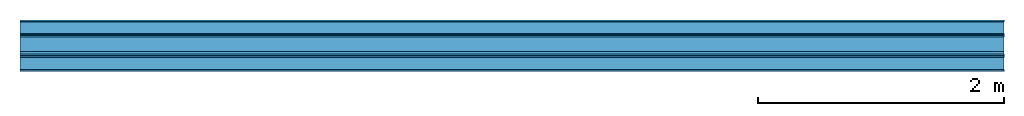
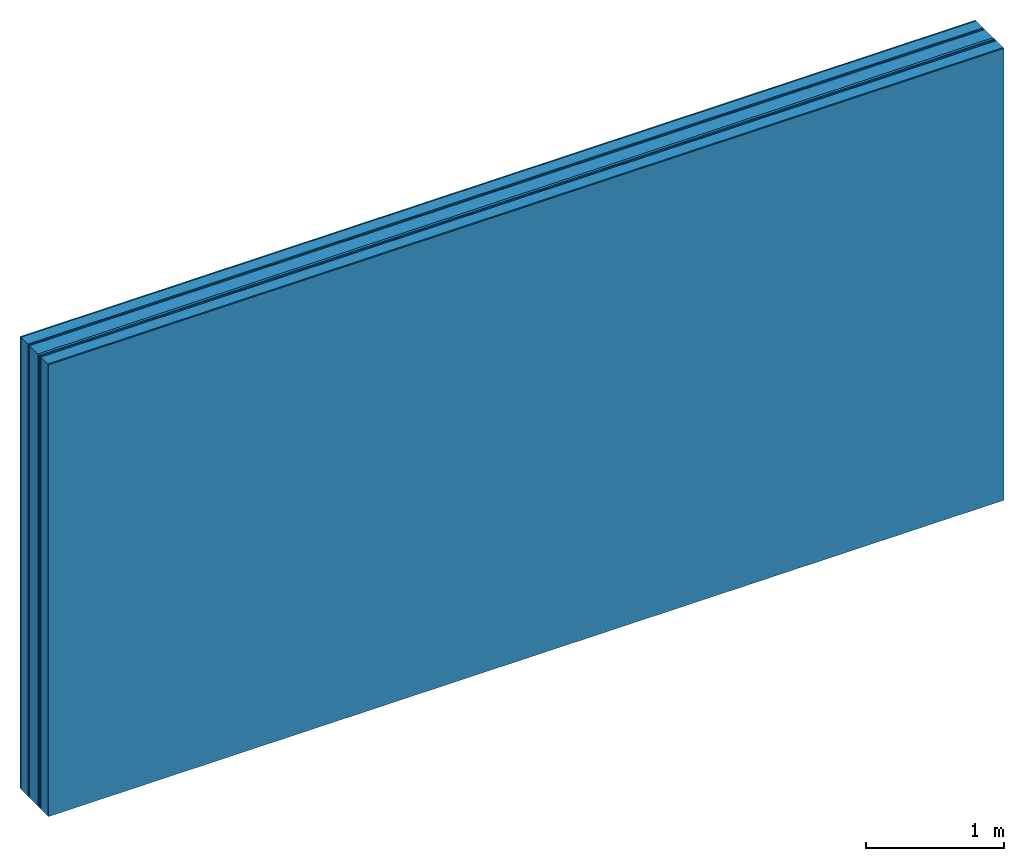
# One storey: 8 plates, 2 members, 1 element without a shape of its own.
"""IFC4 building model written with IfcOpenShell, lengths in metres."""

import ifcopenshell
import ifcopenshell.guid

model = None  # the IFC model being written
_history = None  # IfcOwnerHistory: only IFC2X3 demands one
_inside = {}  # id of a spatial element -> (the spatial element, [elements in it])
_under = {}  # id of a project, library or spatial element -> (it, [spatial elements below it])
_declared = {}  # id of a project -> (the project, [libraries it declares])
_typed = {}  # id of a type object -> (the type object, [elements of that type])
_made_of = {}  # id of a material, layer set ... -> (it, [elements and type objects made of it])


def new_model(schema):
    """Start an empty IFC model of exactly this schema.

    Asked for "IFC4X3", IfcOpenShell would pick the latest addendum, in which some entities
    have other attributes; the version numbers below select the first issue.
    IFC2X3 requires an IfcOwnerHistory on every rooted entity: one is made here for all.
    """
    global model, _history
    if schema == "IFC4X3":
        model = ifcopenshell.file(schema_version=(4, 3, 0, 0))
    else:
        model = ifcopenshell.file(schema=schema)
    _inside.clear()
    _under.clear()
    _declared.clear()
    _typed.clear()
    _made_of.clear()
    _history = None
    if model.schema == "IFC2X3":
        org = make("IfcOrganization", Name="unknown")
        user = make(
            "IfcPersonAndOrganization",
            ThePerson=make("IfcPerson", FamilyName="unknown"),
            TheOrganization=org,
        )
        app = make(
            "IfcApplication",
            ApplicationDeveloper=org,
            Version="unknown",
            ApplicationFullName="unknown",
            ApplicationIdentifier="unknown",
        )
        _history = make(
            "IfcOwnerHistory",
            OwningUser=user,
            OwningApplication=app,
            ChangeAction="ADDED",
            CreationDate=0,
        )
    return model


def make(cls, **values):
    """One entity of the class cls with the attributes given. An attribute that is None is left unset."""
    return model.create_entity(
        cls, **{name: value for name, value in values.items() if value is not None}
    )


def rooted(cls, **values):
    """An entity with a GlobalId (a new one), such as an element, a storey or a relation."""
    return make(cls, GlobalId=ifcopenshell.guid.new(), OwnerHistory=_history, **values)


def si_unit(unit_type, name, prefix=None):
    """IfcSIUnit, for example si_unit("LENGTHUNIT", "METRE", prefix="MILLI")."""
    return make("IfcSIUnit", UnitType=unit_type, Prefix=prefix, Name=name)


def derived_unit(unit_type, elements):
    """IfcDerivedUnit: a product of units, each with its exponent."""
    return make(
        "IfcDerivedUnit",
        Elements=[
            make("IfcDerivedUnitElement", Unit=unit, Exponent=power)
            for unit, power in elements
        ],
        UnitType=unit_type,
    )


def assignment(units):
    """IfcUnitAssignment: the units of a project."""
    return None if units is None else make("IfcUnitAssignment", Units=units)


def point(xyz):
    """IfcCartesianPoint."""
    return None if xyz is None else make("IfcCartesianPoint", Coordinates=xyz)


def direction(xyz):
    """IfcDirection."""
    return None if xyz is None else make("IfcDirection", DirectionRatios=xyz)


def frame(location, z_axis=None, x_axis=None):
    """IfcAxis2Placement3D, a coordinate frame: its origin and axes. An axis left out is left unset."""
    return make(
        "IfcAxis2Placement3D",
        Location=point(location),
        Axis=direction(z_axis),
        RefDirection=direction(x_axis),
    )


def frame_2d(location, x_axis=None):
    """IfcAxis2Placement2D, a coordinate frame in the plane: its origin and x axis."""
    return make(
        "IfcAxis2Placement2D", Location=point(location), RefDirection=direction(x_axis)
    )


def origin():
    """The frame at (0, 0, 0) with its axes left unset."""
    return frame((0.0, 0.0, 0.0))


def origin_with_axes():
    """The frame at (0, 0, 0) with the z axis (0, 0, 1) and the x axis (1, 0, 0) written out."""
    return frame((0.0, 0.0, 0.0), z_axis=(0.0, 0.0, 1.0), x_axis=(1.0, 0.0, 0.0))


def place(relative_to, where):
    """IfcLocalPlacement: puts the frame where relative to a parent placement (None: the world)."""
    return make(
        "IfcLocalPlacement", PlacementRelTo=relative_to, RelativePlacement=where
    )


def context(
    kind, dimensions, precision=None, world=None, true_north=None, identifier=None
):
    """IfcGeometricRepresentationContext, for example the 3D "Model" context."""
    return make(
        "IfcGeometricRepresentationContext",
        ContextIdentifier=identifier,
        ContextType=kind,
        CoordinateSpaceDimension=dimensions,
        Precision=precision,
        WorldCoordinateSystem=world,
        TrueNorth=true_north,
    )


def project(units=None, contexts=None):
    """IfcProject with its units and contexts."""
    return rooted(
        "IfcProject",
        Name="project",
        RepresentationContexts=contexts,
        UnitsInContext=assignment(units),
    )


def spatial(cls, under=None, at=None, **own):
    """A site, building, storey or space (cls), placed at a placement, below another one or the project."""
    s = rooted(cls, ObjectPlacement=at, **own)
    if under is not None:
        _under.setdefault(under.id(), (under, []))[1].append(s)
    return s


def profile(cls, at=None, kind="AREA", **sizes):
    """A parametric profile (cls). Its sizes go by their IFC names, for example OverallWidth=200.0."""
    return make(cls, ProfileType=kind, Position=at, **sizes)


def rectangle(**sizes):
    """IfcRectangleProfileDef."""
    return profile("IfcRectangleProfileDef", **sizes)


def extrude(swept, where, along, depth):
    """IfcExtrudedAreaSolid: the profile swept, set in the frame where, extruded along a direction by depth."""
    return make(
        "IfcExtrudedAreaSolid",
        SweptArea=swept,
        Position=where,
        ExtrudedDirection=direction(along),
        Depth=depth,
    )


def shape(context_of_items, identifier, shape_type, items):
    """IfcShapeRepresentation: the items that make up one representation, for example the "Body"."""
    return make(
        "IfcShapeRepresentation",
        ContextOfItems=context_of_items,
        RepresentationIdentifier=identifier,
        RepresentationType=shape_type,
        Items=items,
    )


def material(Name=None, Category=None):
    """IfcMaterial."""
    return make("IfcMaterial", Name=Name, Category=Category)


def layer(
    of_material, thickness, ventilated=None, Name=None, Category=None, Priority=None
):
    """IfcMaterialLayer: one layer of a wall or slab, of a material (None: an air gap)."""
    return make(
        "IfcMaterialLayer",
        Material=of_material,
        LayerThickness=thickness,
        IsVentilated=ventilated,
        Name=Name,
        Category=Category,
        Priority=Priority,
    )


def layer_set(layers, Name=None):
    """IfcMaterialLayerSet."""
    return make("IfcMaterialLayerSet", MaterialLayers=layers, LayerSetName=Name)


def made_of(thing, what):
    """Note that an element or type object is made of a material, layer set ...; save() writes the relation."""
    if what is not None:
        _made_of.setdefault(what.id(), (what, []))[1].append(thing)
    return thing


def type_object(cls, material=None, **own):
    """A type object (cls), such as IfcWallType, which elements share."""
    return made_of(rooted(cls, **own), material)


def element(
    cls,
    number,
    at=None,
    inside=None,
    cuts=None,
    type_object=None,
    material=None,
    context=None,
    identifier="Body",
    shape_type=None,
    held_by="IfcProductDefinitionShape",
    body=None,
    shapes=None,
    **own,
):
    """One element of the class cls, such as IfcWall. Its Tag is "e" and its number.

    at: its placement. inside: the storey or other place that contains it. cuts: it is an
    opening in that element (IfcRelVoidsElement). A single representation is given by context,
    identifier, shape_type and body (its items); several are given by shapes. held_by: the class
    of the entity that holds the representations. save() writes the other relations.
    """
    e = rooted(cls, Tag="e%d" % number, ObjectPlacement=at, **own)
    if body is not None:
        shapes = [shape(context, identifier, shape_type, body)]
    if shapes is not None:
        e.Representation = make(held_by, Representations=shapes)
    if inside is not None:
        _inside.setdefault(inside.id(), (inside, []))[1].append(e)
    if cuts is not None:
        rooted(
            "IfcRelVoidsElement", RelatingBuildingElement=cuts, RelatedOpeningElement=e
        )
    if type_object is not None:
        _typed.setdefault(type_object.id(), (type_object, []))[1].append(e)
    return made_of(e, material)


def aggregate(whole, parts):
    """IfcRelAggregates: a whole, such as a stair, and the parts it consists of."""
    return rooted("IfcRelAggregates", RelatingObject=whole, RelatedObjects=parts)


def save(model, path):
    """Write the relations noted so far, then the file.

    IfcRelAggregates (storeys below a building ...), IfcRelContainedInSpatialStructure (elements
    in a storey), IfcRelDefinesByType, IfcRelAssociatesMaterial and IfcRelDeclares: one each for
    every whole, place, type object, material and project.
    """
    for whole, parts in _under.values():
        aggregate(whole, parts)
    for where, things in _inside.values():
        rooted(
            "IfcRelContainedInSpatialStructure",
            RelatedElements=things,
            RelatingStructure=where,
        )
    for kind, things in _typed.values():
        rooted("IfcRelDefinesByType", RelatedObjects=things, RelatingType=kind)
    for what, things in _made_of.values():
        rooted("IfcRelAssociatesMaterial", RelatedObjects=things, RelatingMaterial=what)
    for by, libraries in _declared.values():
        rooted("IfcRelDeclares", RelatingContext=by, RelatedDefinitions=libraries)
    model.write(path)


model = new_model("IFC4")

# Units and contexts
plan_context = context("Plan", 3, precision=1e-05, world=origin(), true_north=direction((0.0, 1.0)))
model_context = context("Model", 3, precision=1e-05, world=origin(), true_north=direction((0.0, 1.0)))
ifc_project = project(units=[si_unit("LENGTHUNIT", "METRE"), derived_unit("SOUNDPRESSUREUNIT", [(si_unit("PRESSUREUNIT", "PASCAL", prefix="MICRO"), 0)]), si_unit("ENERGYUNIT", "JOULE", prefix="MEGA"), si_unit("MASSUNIT", "GRAM", prefix="KILO"), derived_unit("THERMALTRANSMITTANCEUNIT", [(si_unit("POWERUNIT", "WATT"), 1), (si_unit("AREAUNIT", "SQUARE_METRE"), -1), (si_unit("THERMODYNAMICTEMPERATUREUNIT", "KELVIN"), -1)]), derived_unit("AREADENSITYUNIT", [(si_unit("MASSUNIT", "GRAM", prefix="KILO"), 1), (si_unit("AREAUNIT", "SQUARE_METRE"), -1)]), derived_unit("USERDEFINED", [(si_unit("ENERGYUNIT", "JOULE", prefix="MEGA"), 1), (si_unit("AREAUNIT", "SQUARE_METRE"), -1)])], contexts=[plan_context, model_context])

# Site, building, storey
site = spatial("IfcSite", under=ifc_project)
building_placement = place(None, origin())
building = spatial("IfcBuilding", under=site, at=building_placement)
storey_placement = place(building_placement, origin())
storey = spatial("IfcBuildingStorey", under=building, at=storey_placement)

# Wall, members, plates
ifc_material_1 = material(Name="joints", Category="04.017")
ifc_layer_1 = layer(ifc_material_1, 0.0, Name="Surface")
ifc_material_2 = material(Name="Rigidur H", Category="03.007")
ifc_layer_2 = layer(ifc_material_2, 0.0125, Name="room side 1st layer")
ifc_material_3 = material(Name="of the art")
ifc_layer_3 = layer(ifc_material_3, 0.0, Name="Bond")
ifc_layer_4 = layer(None, 0.1, Name="Support")
ifc_layer_5 = layer(ifc_material_3, 0.0, Name="Bond")
ifc_layer_6 = layer(ifc_material_2, 0.0125, Name="outside 1st layer")
ifc_layer_7 = layer(ifc_material_2, 0.0125, Name="outside 2nd layer")
ifc_material_4 = material(Category="10.008")
ifc_layer_8 = layer(ifc_material_4, 0.12, Name="Intermediate insulation")
ifc_material_5 = material(Name="Air")
ifc_layer_9 = layer(ifc_material_5, 0.02, Name="Air gap")
ifc_layer_10 = layer(ifc_material_2, 0.0125, Name="2nd layer")
ifc_layer_11 = layer(ifc_material_2, 0.0125, Name="outside 1st layer")
ifc_layer_12 = layer(ifc_material_3, 0.0, Name="Bond")
ifc_layer_13 = layer(None, 0.1, Name="Support")
ifc_layer_14 = layer(ifc_material_3, 0.0, Name="Bond")
ifc_layer_15 = layer(ifc_material_2, 0.0125, Name="room side 1st layer")
ifc_layer_16 = layer(ifc_material_1, 0.0, Name="Surface")
ifc_layer_set = layer_set([ifc_layer_1, ifc_layer_2, ifc_layer_3, ifc_layer_4, ifc_layer_5, ifc_layer_6, ifc_layer_7, ifc_layer_8, ifc_layer_9, ifc_layer_10, ifc_layer_11, ifc_layer_12, ifc_layer_13, ifc_layer_14, ifc_layer_15, ifc_layer_16])
wall_type = type_object("IfcWallType", Name="B0324", PredefinedType="NOTDEFINED", material=ifc_layer_set)
wall_placement = place(None, frame((0.0, 0.0, 0.0), z_axis=(0.0, -1.0, 0.0), x_axis=(1.0, 0.0, 0.0)))
wall = element("IfcWall", 1, at=wall_placement, inside=storey, type_object=wall_type, material=ifc_layer_set, Name="Wall #1")
ifc_material_6 = material(Name="OSB")
member_1_placement = place(wall_placement, origin())
member_1 = element("IfcMember", 2, at=member_1_placement, material=ifc_material_6, Name="Support", context=plan_context, shape_type="SweptSolid", body=[
    extrude(rectangle(XDim=1.0, YDim=0.1, at=frame_2d((0.5, 0.05), x_axis=(1.0, 0.0))), frame((0.0, 4.0, 0.0125), z_axis=(0.0, -1.0, 0.0), x_axis=(1.0, 0.0, 0.0)), (0.0, 0.0, 1.0), 4.0),
    extrude(rectangle(XDim=1.0, YDim=0.1, at=frame_2d((0.5, 0.05), x_axis=(1.0, 0.0))), frame((1.0, 4.0, 0.0125), z_axis=(0.0, -1.0, 0.0), x_axis=(1.0, 0.0, 0.0)), (0.0, 0.0, 1.0), 4.0),
    extrude(rectangle(XDim=1.0, YDim=0.1, at=frame_2d((0.5, 0.05), x_axis=(1.0, 0.0))), frame((2.0, 4.0, 0.0125), z_axis=(0.0, -1.0, 0.0), x_axis=(1.0, 0.0, 0.0)), (0.0, 0.0, 1.0), 4.0),
    extrude(rectangle(XDim=1.0, YDim=0.1, at=frame_2d((0.5, 0.05), x_axis=(1.0, 0.0))), frame((3.0, 4.0, 0.0125), z_axis=(0.0, -1.0, 0.0), x_axis=(1.0, 0.0, 0.0)), (0.0, 0.0, 1.0), 4.0),
    extrude(rectangle(XDim=1.0, YDim=0.1, at=frame_2d((0.5, 0.05), x_axis=(1.0, 0.0))), frame((4.0, 4.0, 0.0125), z_axis=(0.0, -1.0, 0.0), x_axis=(1.0, 0.0, 0.0)), (0.0, 0.0, 1.0), 4.0),
    extrude(rectangle(XDim=1.0, YDim=0.1, at=frame_2d((0.5, 0.05), x_axis=(1.0, 0.0))), frame((5.0, 4.0, 0.0125), z_axis=(0.0, -1.0, 0.0), x_axis=(1.0, 0.0, 0.0)), (0.0, 0.0, 1.0), 4.0),
    extrude(rectangle(XDim=1.0, YDim=0.1, at=frame_2d((0.5, 0.05), x_axis=(1.0, 0.0))), frame((6.0, 4.0, 0.0125), z_axis=(0.0, -1.0, 0.0), x_axis=(1.0, 0.0, 0.0)), (0.0, 0.0, 1.0), 4.0),
    extrude(rectangle(XDim=1.0, YDim=0.1, at=frame_2d((0.5, 0.05), x_axis=(1.0, 0.0))), frame((7.0, 4.0, 0.0125), z_axis=(0.0, -1.0, 0.0), x_axis=(1.0, 0.0, 0.0)), (0.0, 0.0, 1.0), 4.0),
])
member_2_placement = place(wall_placement, origin())
member_2 = element("IfcMember", 3, at=member_2_placement, material=ifc_material_6, Name="Support", context=plan_context, shape_type="SweptSolid", body=[
    extrude(rectangle(XDim=1.0, YDim=0.1, at=frame_2d((0.5, 0.05), x_axis=(1.0, 0.0))), frame((0.0, 4.0, 0.3025), z_axis=(0.0, -1.0, 0.0), x_axis=(1.0, 0.0, 0.0)), (0.0, 0.0, 1.0), 4.0),
    extrude(rectangle(XDim=1.0, YDim=0.1, at=frame_2d((0.5, 0.05), x_axis=(1.0, 0.0))), frame((1.0, 4.0, 0.3025), z_axis=(0.0, -1.0, 0.0), x_axis=(1.0, 0.0, 0.0)), (0.0, 0.0, 1.0), 4.0),
    extrude(rectangle(XDim=1.0, YDim=0.1, at=frame_2d((0.5, 0.05), x_axis=(1.0, 0.0))), frame((2.0, 4.0, 0.3025), z_axis=(0.0, -1.0, 0.0), x_axis=(1.0, 0.0, 0.0)), (0.0, 0.0, 1.0), 4.0),
    extrude(rectangle(XDim=1.0, YDim=0.1, at=frame_2d((0.5, 0.05), x_axis=(1.0, 0.0))), frame((3.0, 4.0, 0.3025), z_axis=(0.0, -1.0, 0.0), x_axis=(1.0, 0.0, 0.0)), (0.0, 0.0, 1.0), 4.0),
    extrude(rectangle(XDim=1.0, YDim=0.1, at=frame_2d((0.5, 0.05), x_axis=(1.0, 0.0))), frame((4.0, 4.0, 0.3025), z_axis=(0.0, -1.0, 0.0), x_axis=(1.0, 0.0, 0.0)), (0.0, 0.0, 1.0), 4.0),
    extrude(rectangle(XDim=1.0, YDim=0.1, at=frame_2d((0.5, 0.05), x_axis=(1.0, 0.0))), frame((5.0, 4.0, 0.3025), z_axis=(0.0, -1.0, 0.0), x_axis=(1.0, 0.0, 0.0)), (0.0, 0.0, 1.0), 4.0),
    extrude(rectangle(XDim=1.0, YDim=0.1, at=frame_2d((0.5, 0.05), x_axis=(1.0, 0.0))), frame((6.0, 4.0, 0.3025), z_axis=(0.0, -1.0, 0.0), x_axis=(1.0, 0.0, 0.0)), (0.0, 0.0, 1.0), 4.0),
    extrude(rectangle(XDim=1.0, YDim=0.1, at=frame_2d((0.5, 0.05), x_axis=(1.0, 0.0))), frame((7.0, 4.0, 0.3025), z_axis=(0.0, -1.0, 0.0), x_axis=(1.0, 0.0, 0.0)), (0.0, 0.0, 1.0), 4.0),
])
plate_1_placement = place(wall_placement, origin())
plate_1 = element("IfcPlate", 4, at=plate_1_placement, material=ifc_material_2, Name="room side 1st layer", context=plan_context, shape_type="SweptSolid", body=[
    extrude(rectangle(XDim=8.0, YDim=4.0, at=frame_2d((4.0, 2.0), x_axis=(1.0, 0.0))), origin_with_axes(), (0.0, 0.0, 1.0), 0.0125),
])
plate_2_placement = place(wall_placement, origin())
plate_2 = element("IfcPlate", 5, at=plate_2_placement, material=ifc_material_2, Name="outside 1st layer", context=plan_context, shape_type="SweptSolid", body=[
    extrude(rectangle(XDim=8.0, YDim=4.0, at=frame_2d((4.0, 2.0), x_axis=(1.0, 0.0))), frame((0.0, 0.0, 0.1125), z_axis=(0.0, 0.0, 1.0), x_axis=(1.0, 0.0, 0.0)), (0.0, 0.0, 1.0), 0.0125),
])
plate_3_placement = place(wall_placement, origin())
plate_3 = element("IfcPlate", 6, at=plate_3_placement, material=ifc_material_2, Name="outside 2nd layer", context=plan_context, shape_type="SweptSolid", body=[
    extrude(rectangle(XDim=8.0, YDim=4.0, at=frame_2d((4.0, 2.0), x_axis=(1.0, 0.0))), frame((0.0, 0.0, 0.125), z_axis=(0.0, 0.0, 1.0), x_axis=(1.0, 0.0, 0.0)), (0.0, 0.0, 1.0), 0.0125),
])
plate_4_placement = place(wall_placement, origin())
plate_4 = element("IfcPlate", 7, at=plate_4_placement, material=ifc_material_4, Name="Intermediate insulation", context=plan_context, shape_type="SweptSolid", body=[
    extrude(rectangle(XDim=8.0, YDim=4.0, at=frame_2d((4.0, 2.0), x_axis=(1.0, 0.0))), frame((0.0, 0.0, 0.1375), z_axis=(0.0, 0.0, 1.0), x_axis=(1.0, 0.0, 0.0)), (0.0, 0.0, 1.0), 0.12),
])
plate_5_placement = place(wall_placement, origin())
plate_5 = element("IfcPlate", 8, at=plate_5_placement, material=ifc_material_5, Name="Air gap", context=plan_context, shape_type="SweptSolid", body=[
    extrude(rectangle(XDim=8.0, YDim=4.0, at=frame_2d((4.0, 2.0), x_axis=(1.0, 0.0))), frame((0.0, 0.0, 0.2575), z_axis=(0.0, 0.0, 1.0), x_axis=(1.0, 0.0, 0.0)), (0.0, 0.0, 1.0), 0.02),
])
plate_6_placement = place(wall_placement, origin())
plate_6 = element("IfcPlate", 9, at=plate_6_placement, material=ifc_material_2, Name="2nd layer", context=plan_context, shape_type="SweptSolid", body=[
    extrude(rectangle(XDim=8.0, YDim=4.0, at=frame_2d((4.0, 2.0), x_axis=(1.0, 0.0))), frame((0.0, 0.0, 0.2775), z_axis=(0.0, 0.0, 1.0), x_axis=(1.0, 0.0, 0.0)), (0.0, 0.0, 1.0), 0.0125),
])
plate_7_placement = place(wall_placement, origin())
plate_7 = element("IfcPlate", 10, at=plate_7_placement, material=ifc_material_2, Name="outside 1st layer", context=plan_context, shape_type="SweptSolid", body=[
    extrude(rectangle(XDim=8.0, YDim=4.0, at=frame_2d((4.0, 2.0), x_axis=(1.0, 0.0))), frame((0.0, 0.0, 0.29), z_axis=(0.0, 0.0, 1.0), x_axis=(1.0, 0.0, 0.0)), (0.0, 0.0, 1.0), 0.0125),
])
plate_8_placement = place(wall_placement, origin())
plate_8 = element("IfcPlate", 11, at=plate_8_placement, material=ifc_material_2, Name="room side 1st layer", context=plan_context, shape_type="SweptSolid", body=[
    extrude(rectangle(XDim=8.0, YDim=4.0, at=frame_2d((4.0, 2.0), x_axis=(1.0, 0.0))), frame((0.0, 0.0, 0.4025), z_axis=(0.0, 0.0, 1.0), x_axis=(1.0, 0.0, 0.0)), (0.0, 0.0, 1.0), 0.0125),
])
aggregate(wall, [plate_1, member_1, plate_2, plate_3, plate_4, plate_5, plate_6, plate_7, member_2, plate_8])

save(model, "model.ifc")
